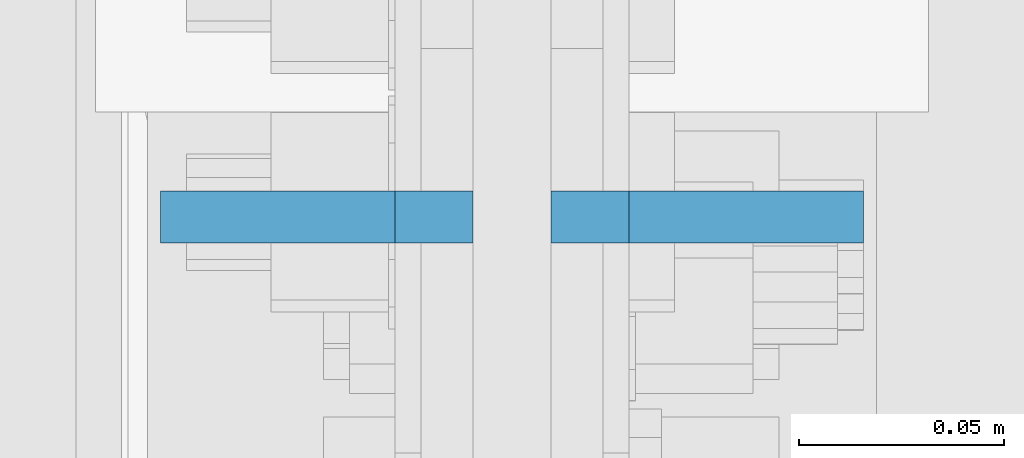
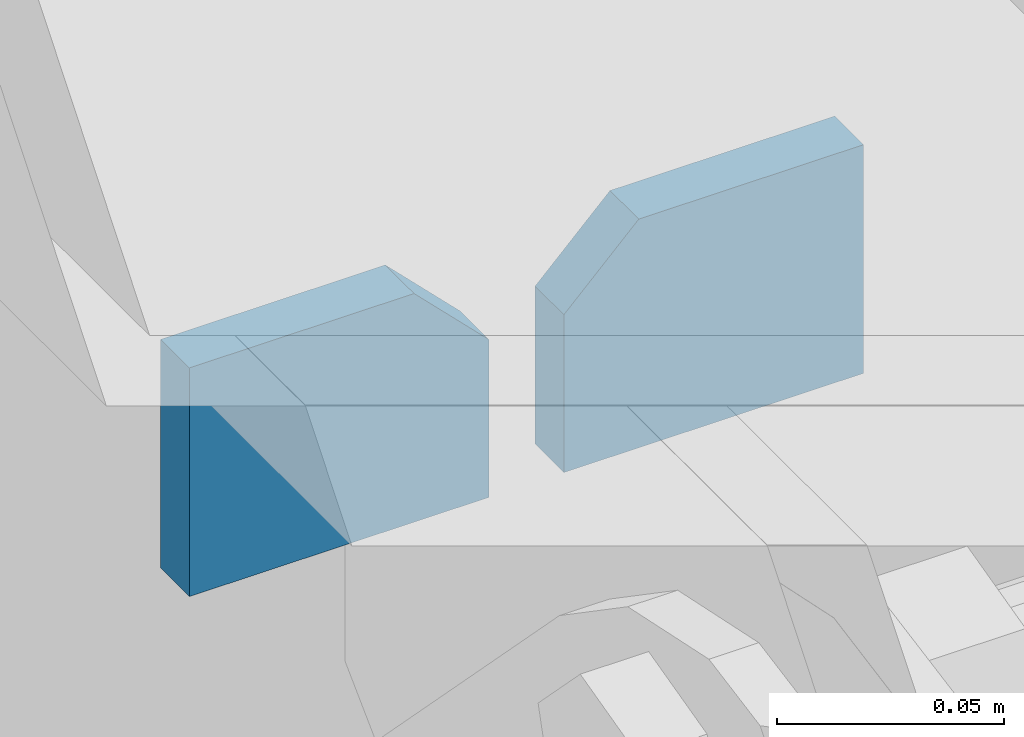
# One storey, part 1124 of 1179: 2 plates, 1 element without a shape of its own.
"""IFC2X3 building model written with IfcOpenShell, lengths in millimetres."""

from ifc_helpers import new_model, si_unit, frame, origin_with_axes, place, context, subcontext, project, spatial, faceted_brep, material, type_object, element, aggregate, save


model = new_model("IFC2X3")

# Units and contexts
model_context = context("Model", 3, precision=1e-05, world=origin_with_axes())
body_context = subcontext(model_context, "Body", "Model", "MODEL_VIEW")
ifc_project = project(units=[si_unit("LENGTHUNIT", "METRE", prefix="MILLI"), si_unit("AREAUNIT", "SQUARE_METRE"), si_unit("VOLUMEUNIT", "CUBIC_METRE"), si_unit("MASSUNIT", "GRAM", prefix="KILO"), si_unit("TIMEUNIT", "SECOND"), si_unit("PLANEANGLEUNIT", "RADIAN"), si_unit("SOLIDANGLEUNIT", "STERADIAN"), si_unit("THERMODYNAMICTEMPERATUREUNIT", "DEGREE_CELSIUS"), si_unit("LUMINOUSINTENSITYUNIT", "LUMEN")], contexts=[model_context])

# Site, building, storey
site_placement = place(None, origin_with_axes())
site = spatial("IfcSite", under=ifc_project, at=site_placement, CompositionType="ELEMENT")
building_placement = place(site_placement, origin_with_axes())
building = spatial("IfcBuilding", under=site, at=building_placement, Name="Undefined", CompositionType="ELEMENT")
storey_placement = place(building_placement, origin_with_axes())
storey = spatial("IfcBuildingStorey", under=building, at=storey_placement, Name="Undefined", CompositionType="ELEMENT", Elevation=0.0)

# Assembly, plates
assembly_placement = place(storey_placement, origin_with_axes())
assembly = element("IfcElementAssembly", 1, at=assembly_placement, inside=storey, Name="BEAM", AssemblyPlace="NOTDEFINED", PredefinedType="RIGID_FRAME")
ifc_material = material(Name="STEEL/A572-GR.50")
plate_type = type_object("IfcPlateType", PredefinedType="NOTDEFINED")
plate_1_placement = place(assembly_placement, frame((24298.275, 15773.4, 7683.499999623), z_axis=(-1.0, 0.0, 0.0), x_axis=(0.0, 0.0, -1.0)))
plate_1 = element("IfcPlate", 2, at=plate_1_placement, type_object=plate_type, material=ifc_material, Name="PLATE", context=body_context, shape_type="Brep", body=[
    faceted_brep([(0.0, 6.35000000000036, 19.0499999999993), (19.0500000000002, 6.35000000000036, 0.0), (19.0500000000002, -6.35000000000036, 0.0), (0.0, -6.35000000000036, 19.0499999999993), (0.0, -6.35000000000036, 76.2000000000044), (0.0, 6.35000000000036, 76.2000000000044), (61.493348936805, -6.35000000000036, 76.2000000000044), (61.493348936805, 6.35000000000036, 76.2000000000044), (61.493348936805, -6.35000000000036, 0.0), (61.493348936805, 6.35000000000036, 0.0)], [[[0, 1, 2, 3]], [[4, 5, 0, 3]], [[4, 6, 7, 5]], [[6, 8, 9, 7]], [[9, 8, 2, 1]], [[5, 7, 9, 1, 0]], [[8, 6, 4, 3, 2]]]),
])
plate_2_placement = place(assembly_placement, frame((24317.325, 15773.4, 7683.499999623), z_axis=(1.0, 0.0, 0.0), x_axis=(0.0, 0.0, -1.0)))
plate_2 = element("IfcPlate", 3, at=plate_2_placement, type_object=plate_type, material=ifc_material, Name="PLATE", context=body_context, shape_type="Brep", body=[
    faceted_brep([(0.0, 6.35000000000036, 19.0499999999993), (19.0500000000002, 6.35000000000036, 0.0), (19.0500000000002, -6.35000000000036, 0.0), (0.0, -6.35000000000036, 19.0499999999993), (0.0, -6.35000000000036, 76.2000000000044), (0.0, 6.35000000000036, 76.2000000000044), (61.493348936805, -6.35000000000036, 76.2000000000044), (61.493348936805, 6.35000000000036, 76.2000000000044), (61.493348936805, -6.35000000000036, 0.0), (61.493348936805, 6.35000000000036, 0.0)], [[[0, 1, 2, 3]], [[4, 5, 0, 3]], [[4, 6, 7, 5]], [[6, 8, 9, 7]], [[9, 8, 2, 1]], [[5, 7, 9, 1, 0]], [[8, 6, 4, 3, 2]]]),
])
aggregate(assembly, [plate_1, plate_2])

save(model, "model.ifc")
